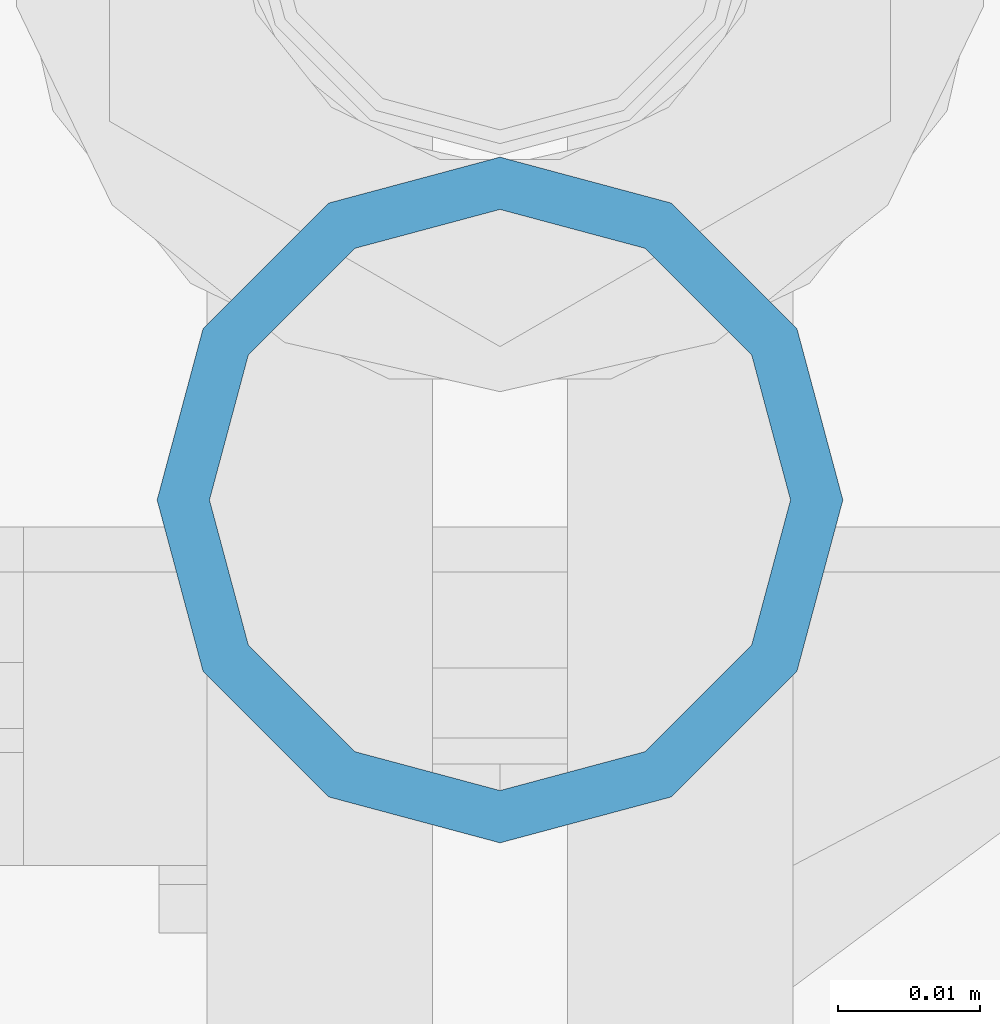
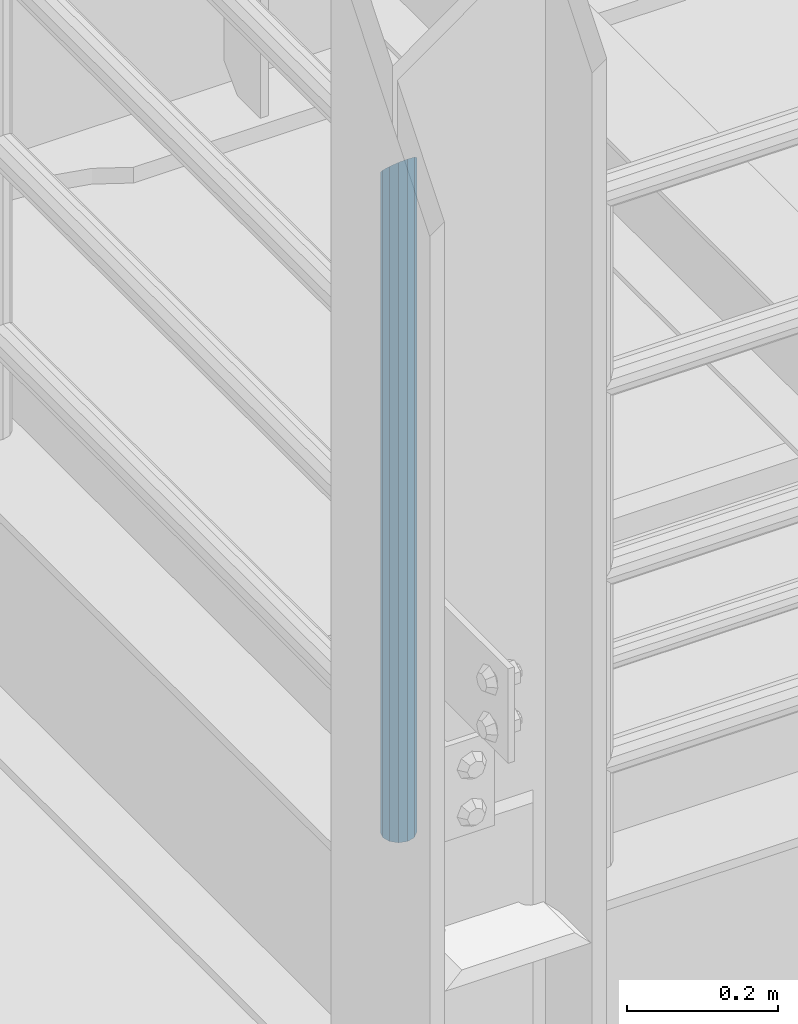
# One storey, part 563 of 1876: 1 column, 1 element without a shape of its own.
"""IFC2X3 building model written with IfcOpenShell, lengths in millimetres."""

from ifc_helpers import new_model, si_unit, frame, origin_with_axes, place, context, subcontext, project, spatial, faceted_brep, material, type_object, element, aggregate, save


model = new_model("IFC2X3")

# Units and contexts
model_context = context("Model", 3, precision=1e-05, world=origin_with_axes())
body_context = subcontext(model_context, "Body", "Model", "MODEL_VIEW")
ifc_project = project(units=[si_unit("LENGTHUNIT", "METRE", prefix="MILLI"), si_unit("AREAUNIT", "SQUARE_METRE"), si_unit("VOLUMEUNIT", "CUBIC_METRE"), si_unit("MASSUNIT", "GRAM", prefix="KILO"), si_unit("TIMEUNIT", "SECOND"), si_unit("PLANEANGLEUNIT", "RADIAN"), si_unit("SOLIDANGLEUNIT", "STERADIAN"), si_unit("THERMODYNAMICTEMPERATUREUNIT", "DEGREE_CELSIUS"), si_unit("LUMINOUSINTENSITYUNIT", "LUMEN")], contexts=[model_context])

# Site, building, storey
site_placement = place(None, origin_with_axes())
site = spatial("IfcSite", under=ifc_project, at=site_placement, CompositionType="ELEMENT")
building_placement = place(site_placement, origin_with_axes())
building = spatial("IfcBuilding", under=site, at=building_placement, Name="Undefined", CompositionType="ELEMENT")
storey_placement = place(building_placement, origin_with_axes())
storey = spatial("IfcBuildingStorey", under=building, at=storey_placement, Name="Undefined", CompositionType="ELEMENT", Elevation=0.0)

# Assembly, column
assembly_placement = place(storey_placement, origin_with_axes())
assembly = element("IfcElementAssembly", 1, at=assembly_placement, inside=storey, Name="RAIL", AssemblyPlace="NOTDEFINED", PredefinedType="RIGID_FRAME")
ifc_material = material()
column_type = type_object("IfcColumnType", Name="PIPE1-1/2SCH40", PredefinedType="NOTDEFINED")
column_placement = place(assembly_placement, frame((2.72848410531878e-12, -6925.945, 17983.2), z_axis=(0.0, 1.0, 0.0), x_axis=(0.0, 0.0, 1.0)))
column = element("IfcColumn", 2, at=column_placement, type_object=column_type, material=ifc_material, Name="POST", ObjectType="PIPE1-1/2SCH40", context=body_context, shape_type="Brep", body=[
    faceted_brep([(0.0, -20.4469999999999, 0.0), (0.0, -17.7076214311803, 10.2235000000001), (1066.1015, -17.7076214311803, 10.2235000000001), (1076.325, -20.4469999999999, 0.0), (0.0, -10.2235000000001, 17.7076214311801), (1058.61737856882, -10.2235000000001, 17.7076214311801), (-1.45519152283669e-11, 0.0, 20.4470000000001), (1055.878, 0.0, 20.4470000000001), (0.0, 10.2235000000001, 17.7076214311801), (1058.61737856882, 10.2235000000001, 17.7076214311801), (0.0, 17.7076214311803, 10.2235000000001), (1066.1015, 17.7076214311803, 10.2235000000001), (0.0, 20.4469999999999, 0.0), (1076.325, 20.4469999999999, 0.0), (0.0, 17.7076214311803, -10.2235000000001), (1086.5485, 17.7076214311803, -10.2235000000001), (0.0, 10.2235000000001, -17.7076214311801), (1094.03262143118, 10.2235000000001, -17.7076214311801), (-1.45519152283669e-11, 0.0, -20.4470000000001), (1096.772, 0.0, -20.4470000000001), (0.0, -10.2235000000001, -17.7076214311801), (1094.03262143118, -10.2235000000001, -17.7076214311801), (0.0, -17.7076214311803, -10.2235000000001), (1086.5485, -17.7076214311803, -10.2235000000001), (0.0, -24.1299999999992, 0.0), (0.0, -20.8971929933184, -12.0649999999996), (1088.39, -20.8971929933184, -12.0649999999996), (1076.325, -24.1300000000001, 0.0), (0.0, -12.0650000000001, -20.8971929933186), (1097.22219299332, -12.0650000000001, -20.8971929933186), (-1.45519152283669e-11, 0.0, -24.130000000001), (1100.455, 0.0, -24.1300000000001), (0.0, 12.0650000000001, -20.8971929933186), (1097.22219299332, 12.0650000000001, -20.8971929933186), (0.0, 20.8971929933184, -12.0649999999996), (1088.39, 20.8971929933184, -12.0649999999996), (0.0, 24.1299999999992, 0.0), (1076.325, 24.1300000000001, 0.0), (0.0, 20.8971929933184, 12.0649999999996), (1064.26, 20.8971929933184, 12.0649999999996), (0.0, 12.0650000000001, 20.8971929933186), (1055.42780700668, 12.0650000000001, 20.8971929933186), (-1.45519152283669e-11, 0.0, 24.130000000001), (1052.195, 0.0, 24.1300000000001), (0.0, -12.0650000000001, 20.8971929933186), (1055.42780700668, -12.0650000000001, 20.8971929933186), (0.0, -20.8971929933184, 12.0649999999996), (1064.26, -20.8971929933184, 12.0649999999996)], [[[0, 1, 2, 3]], [[1, 4, 5, 2]], [[4, 6, 7, 5]], [[6, 8, 9, 7]], [[8, 10, 11, 9]], [[10, 12, 13, 11]], [[12, 14, 15, 13]], [[14, 16, 17, 15]], [[16, 18, 19, 17]], [[18, 20, 21, 19]], [[20, 22, 23, 21]], [[22, 0, 3, 23]], [[24, 25, 26, 27]], [[25, 28, 29, 26]], [[28, 30, 31, 29]], [[30, 32, 33, 31]], [[32, 34, 35, 33]], [[34, 36, 37, 35]], [[36, 38, 39, 37]], [[38, 40, 41, 39]], [[40, 42, 43, 41]], [[42, 44, 45, 43]], [[44, 46, 47, 45]], [[46, 24, 27, 47]], [[29, 31, 33, 35, 37, 39, 41, 43, 45, 47, 27, 26], [5, 7, 9, 11, 13, 15, 17, 19, 21, 23, 3, 2]], [[46, 44, 42, 40, 38, 36, 34, 32, 30, 28, 25, 24], [22, 20, 18, 16, 14, 12, 10, 8, 6, 4, 1, 0]]]),
])
aggregate(assembly, [column])

save(model, "model.ifc")
